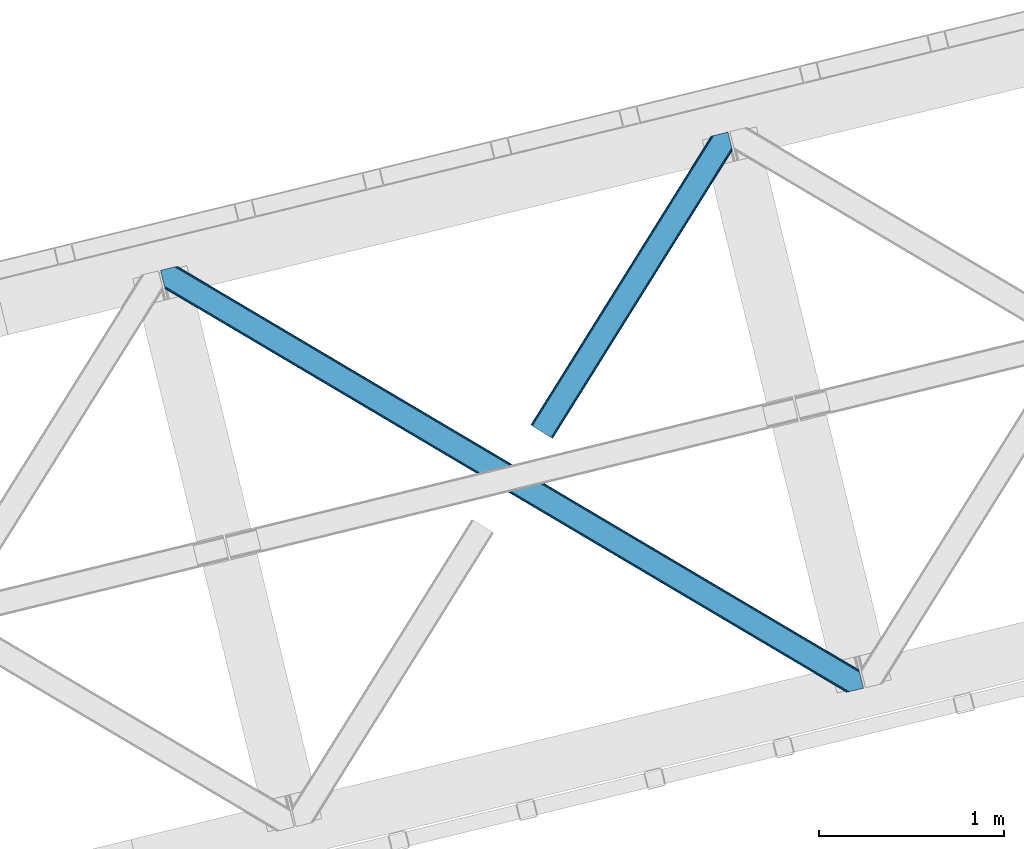
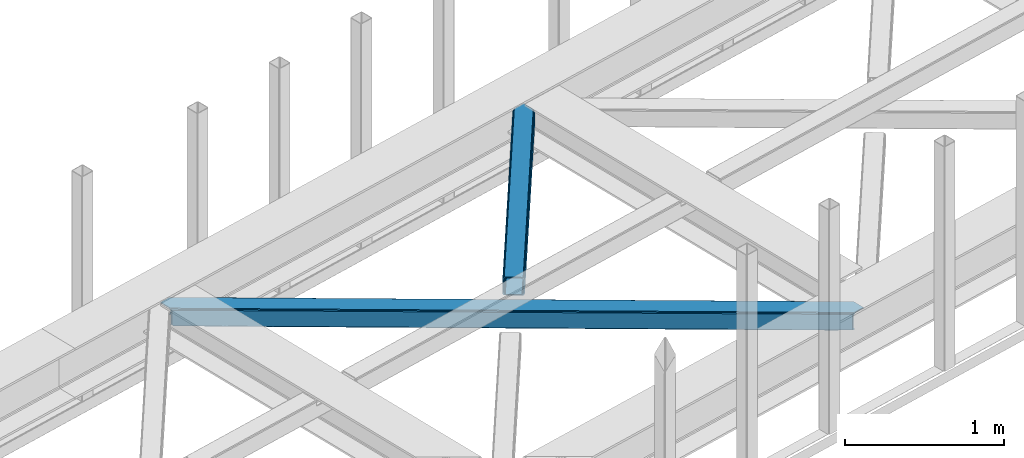
# One storey, part 45 of 67: 2 members.
"""IFC4 building model written with IfcOpenShell, lengths in millimetres."""

from ifc_helpers import new_model, entity, si_unit, converted_unit, derived_unit, direction, frame, origin, place, context, subcontext, project, spatial, triangles, type_object, element, save


model = new_model("IFC4")

# Units and contexts
model_context = context("Model", 3, precision=0.01, world=origin(), true_north=direction((6.12303176911189e-17, 1.0)))
plan_context = context("Plan", 3, precision=0.01, world=origin(), true_north=direction((6.12303176911189e-17, 1.0)))
body_context = subcontext(model_context, "Body", "Model", "MODEL_VIEW")
ifc_project = project(units=[si_unit("LENGTHUNIT", "METRE", prefix="MILLI"), si_unit("AREAUNIT", "SQUARE_METRE"), si_unit("VOLUMEUNIT", "CUBIC_METRE"), converted_unit("PLANEANGLEUNIT", "DEGREE", entity("IfcRatioMeasure", 0.0174532925199433), si_unit("PLANEANGLEUNIT", "RADIAN"), dimensions=[0, 0, 0, 0, 0, 0, 0]), si_unit("MASSUNIT", "GRAM", prefix="KILO"), derived_unit("MASSDENSITYUNIT", [(si_unit("MASSUNIT", "GRAM", prefix="KILO"), 1), (si_unit("LENGTHUNIT", "METRE"), -3)]), derived_unit("MOMENTOFINERTIAUNIT", [(si_unit("LENGTHUNIT", "METRE"), 4)]), si_unit("TIMEUNIT", "SECOND"), si_unit("FREQUENCYUNIT", "HERTZ"), si_unit("THERMODYNAMICTEMPERATUREUNIT", "DEGREE_CELSIUS"), derived_unit("THERMALTRANSMITTANCEUNIT", [(si_unit("MASSUNIT", "GRAM", prefix="KILO"), 1), (si_unit("THERMODYNAMICTEMPERATUREUNIT", "KELVIN"), -1), (si_unit("TIMEUNIT", "SECOND"), -3)]), derived_unit("VOLUMETRICFLOWRATEUNIT", [(si_unit("LENGTHUNIT", "METRE"), 3), (si_unit("TIMEUNIT", "SECOND"), -1)]), derived_unit("MASSFLOWRATEUNIT", [(si_unit("MASSUNIT", "GRAM", prefix="KILO"), 1), (si_unit("TIMEUNIT", "SECOND"), -1)]), derived_unit("ROTATIONALFREQUENCYUNIT", [(si_unit("TIMEUNIT", "SECOND"), -1)]), si_unit("ELECTRICCURRENTUNIT", "AMPERE"), si_unit("ELECTRICVOLTAGEUNIT", "VOLT"), si_unit("POWERUNIT", "WATT"), si_unit("FORCEUNIT", "NEWTON", prefix="KILO"), si_unit("ILLUMINANCEUNIT", "LUX"), si_unit("LUMINOUSFLUXUNIT", "LUMEN"), si_unit("LUMINOUSINTENSITYUNIT", "CANDELA"), derived_unit("USERDEFINED", [(si_unit("MASSUNIT", "GRAM", prefix="KILO"), -1), (si_unit("LENGTHUNIT", "METRE"), -2), (si_unit("TIMEUNIT", "SECOND"), 3), (si_unit("LUMINOUSFLUXUNIT", "LUMEN"), 1)]), derived_unit("LINEARVELOCITYUNIT", [(si_unit("LENGTHUNIT", "METRE"), 1), (si_unit("TIMEUNIT", "SECOND"), -1)]), si_unit("PRESSUREUNIT", "PASCAL"), derived_unit("USERDEFINED", [(si_unit("LENGTHUNIT", "METRE"), -2), (si_unit("MASSUNIT", "GRAM", prefix="KILO"), 1), (si_unit("TIMEUNIT", "SECOND"), -2)]), derived_unit("LINEARFORCEUNIT", [(si_unit("MASSUNIT", "GRAM", prefix="KILO"), 1), (si_unit("LENGTHUNIT", "METRE"), 1), (si_unit("TIMEUNIT", "SECOND"), -2), (si_unit("LENGTHUNIT", "METRE"), -1)]), derived_unit("PLANARFORCEUNIT", [(si_unit("MASSUNIT", "GRAM", prefix="KILO"), 1), (si_unit("LENGTHUNIT", "METRE"), 1), (si_unit("TIMEUNIT", "SECOND"), -2), (si_unit("LENGTHUNIT", "METRE"), -2)])], contexts=[model_context, plan_context])

# Site, building, storey
site_placement = place(None, origin())
site = spatial("IfcSite", under=ifc_project, at=site_placement, CompositionType="ELEMENT")
building_placement = place(site_placement, origin())
building = spatial("IfcBuilding", under=site, at=building_placement, CompositionType="ELEMENT")
storey_placement = place(building_placement, frame((0.0, 0.0, 19800.0)))
storey = spatial("IfcBuildingStorey", under=building, at=storey_placement, CompositionType="ELEMENT", Elevation=19800.0)

# Members
member_type_1 = type_object("IfcMemberType", PredefinedType="BRACE")
member_1_placement = place(storey_placement, frame((-18949.8456481934, 14772.5982971191, 3822.99993896484)))
element("IfcMember", 1, at=member_1_placement, inside=storey, type_object=member_type_1, ObjectType="Steel Horizontal Brace", PredefinedType="BRACE", context=body_context, shape_type="Tessellation", body=[
    triangles([(933.016305541994, 1535.69114685059, 0.0), (967.77581176758, 1393.09054870606, 0.0), (14.8444427490249, 64.8692962646492, 0.0), (103.913424682618, 9.26687622070313, 0.0), (928.799121093751, 1552.99009094238, 5.49966430664063), (928.938647460938, 1552.41570739746, 5.208984375), (930.798999023438, 1544.78594055176, 1.33247680664135), (971.99299621582, 1375.79160461426, 5.49966430664063), (971.852307128906, 1376.36715087891, 5.208984375), (969.993118286133, 1383.99575500488, 1.33247680664135), (972.208099365234, 1375.53813171387, 5.8531311035149), (972.418551635743, 1375.28233337402, 6.20659790039281), (928.911904907229, 1553.56912536621, 5.74383544921875), (972.720858764649, 1375.53696899414, 6.35310058593677), (929.027014160158, 1554.17606506348, 5.9996337890625), (973.022003173828, 1375.79160461426, 6.49960327148438), (929.142123413087, 1554.78300476074, 6.25543212890625), (929.250256347656, 1555.36203918457, 6.49960327148438), (4.34740905761646, 71.4223846435561, 5.12526855468968), (1.13016357422021, 73.4315643310547, 10.8039916992202), (973.355703735353, 1630.84231567383, 10.8039916992202), (976.91130065918, 1631.70854187012, 6.49960327148438), (9.16455688476708, 68.4167541503921, 1.33247680664135), (971.503491210937, 1630.3900177002, 17.5012573242202), (0.0, 74.1373352050796, 17.5012573242202), (1081.09680175781, 1548.91592102051, 6.49960327148438), (1056.20297241211, 1651.03759460449, 6.49960327148438), (971.503491210937, 1630.3900177002, 122.499499511719), (0.0, 74.1373352050796, 122.499499511719), (973.355703735353, 1630.84231567383, 129.196765136719), (1.13016357422021, 73.4315643310547, 129.196765136719), (978.633288574219, 1632.12828369141, 134.87548828125), (4.34740905761646, 71.4223846435561, 134.87548828125), (986.526992797852, 1634.05258483887, 138.668280029298), (9.16455688476708, 68.4167541503921, 138.668280029298), (995.835726928712, 1636.32221374512, 140.00075683594), (14.8444427490249, 64.8692962646492, 140.00075683594), (118.757867431643, 0.0, 17.5012573242202), (117.62886657715, 0.705770874024893, 10.8039916992202), (1085.13725280762, 1551.24949951172, 10.9783996582046), (1087.41153259277, 1552.56337280274, 13.4991760253906), (109.594473266603, 5.7205810546875, 1.33247680664135), (114.410458374023, 2.71495056152344, 5.12526855468968), (1087.56501159668, 1551.93434143066, 17.5012573242202), (1081.77234191895, 1575.70149536133, 140.00075683594), (1063.00372009277, 1652.69447021484, 140.00075683594), (103.913424682618, 9.26687622070313, 140.00075683594), (1083.9896484375, 1566.60553894043, 138.668280029298), (109.594473266603, 5.7205810546875, 138.668280029298), (1085.86860351562, 1558.8955444336, 134.87548828125), (114.410458374023, 2.71495056152344, 134.87548828125), (1087.12434082031, 1553.7435333252, 129.196765136719), (117.62886657715, 0.705770874024893, 129.196765136719), (1087.56501159668, 1551.93434143066, 122.499499511719), (118.757867431643, 0.0, 122.499499511719), (1082.5362487793, 1566.77297058106, 12.1248413085959), (1083.96058044434, 1566.72297363281, 13.4991760253906), (1077.84700012207, 1569.98440246582, 8.3320495605476), (1074.64603271485, 1577.50138549805, 6.99957275390625), (1056.69131469727, 1651.1561920166, 6.99957275390625), (1005.56885375977, 1638.69416198731, 6.99957275390625), (20.7789642333992, 61.1625457763676, 6.99957275390625), (97.9742523193381, 12.9736267089847, 6.99957275390625), (108.471286010743, 6.42053833007958, 12.1248413085959), (111.689694213866, 4.41252136230469, 17.8035644531265), (1084.80704040527, 1563.24992980957, 17.8035644531265), (103.65530090332, 9.42733154296911, 8.3320495605476), (1085.24771118164, 1561.44073791504, 24.5008300781265), (112.818695068359, 3.70675048828161, 24.5008300781265), (983.088830566408, 1633.21426391602, 17.8035644531265), (981.235455322265, 1632.76312866211, 24.5008300781265), (7.06468505859448, 69.7236511230476, 17.8035644531265), (5.93568420410156, 70.4294219970707, 24.5008300781265), (988.366415405275, 1634.50139465332, 12.1248413085959), (10.283093261718, 67.7144714355472, 12.1248413085959), (996.260119628907, 1636.42569580078, 8.3320495605476), (15.0990783691414, 64.7088409423832, 8.3320495605476), (981.235455322265, 1632.76312866211, 115.499926757813), (5.93568420410156, 70.4294219970707, 115.499926757813), (996.260119628907, 1636.42569580078, 131.668707275392), (1005.56885375977, 1638.69416198731, 133.001184082033), (1063.00372009277, 1652.69447021484, 133.001184082033), (988.366415405275, 1634.50139465332, 127.873590087893), (983.088830566408, 1633.21426391602, 122.197192382813), (20.7789642333992, 61.1625457763676, 133.001184082033), (15.0990783691414, 64.7088409423832, 131.668707275392), (10.283093261718, 67.7144714355472, 127.873590087893), (7.06468505859448, 69.7236511230476, 122.197192382813), (108.471286010743, 6.42053833007958, 127.873590087893), (111.689694213866, 4.41252136230469, 122.197192382813), (112.818695068359, 3.70675048828161, 115.499926757813), (97.9742523193381, 12.9736267089847, 133.001184082033), (103.65530090332, 9.42733154296911, 131.668707275392), (1085.24771118164, 1561.44073791504, 115.499926757813), (1084.80704040527, 1563.24992980957, 122.197192382813), (1083.55130310059, 1568.40194091797, 127.873590087893), (1081.67118530273, 1576.11309814453, 131.668707275392), (1079.45504150391, 1585.2078918457, 133.001184082033)], [[1, 2, 3], [4, 3, 2], [1, 5, 2], [6, 5, 1], [1, 7, 6], [2, 5, 8], [8, 9, 2], [10, 2, 9], [11, 8, 5], [12, 11, 13], [14, 12, 15], [16, 14, 17], [17, 18, 16], [15, 17, 14], [13, 15, 12], [5, 13, 11], [17, 19, 18], [19, 17, 15], [13, 19, 15], [19, 13, 5], [5, 6, 19], [20, 21, 18], [18, 19, 20], [21, 22, 18], [19, 6, 7], [7, 1, 23], [3, 23, 1], [7, 23, 19], [24, 21, 20], [20, 25, 24], [18, 26, 16], [26, 18, 22], [27, 26, 22], [28, 24, 25], [25, 29, 28], [30, 28, 31], [29, 31, 28], [32, 30, 33], [31, 33, 30], [34, 32, 35], [33, 35, 32], [36, 34, 37], [35, 37, 34], [38, 39, 40], [40, 41, 38], [42, 10, 9], [39, 12, 16], [16, 40, 39], [16, 26, 40], [9, 39, 43], [9, 12, 39], [9, 43, 42], [2, 10, 4], [42, 4, 10], [41, 44, 38], [45, 36, 37], [36, 45, 46], [37, 47, 45], [48, 45, 47], [47, 49, 48], [50, 48, 49], [49, 51, 50], [52, 50, 51], [51, 53, 52], [54, 52, 53], [53, 55, 54], [44, 54, 38], [55, 38, 54], [56, 40, 26], [41, 40, 56], [56, 57, 41], [58, 26, 59], [26, 58, 56], [60, 59, 26], [59, 61, 62], [61, 59, 60], [62, 63, 59], [64, 65, 66], [66, 57, 64], [58, 59, 63], [63, 67, 58], [56, 58, 67], [67, 64, 56], [57, 56, 64], [68, 66, 65], [65, 69, 68], [70, 71, 72], [73, 72, 71], [74, 70, 75], [72, 75, 70], [76, 74, 77], [75, 77, 74], [61, 76, 62], [77, 62, 76], [71, 78, 79], [79, 73, 71], [34, 36, 80], [46, 81, 36], [81, 46, 82], [81, 80, 36], [83, 34, 80], [83, 32, 34], [32, 84, 30], [84, 32, 83], [28, 84, 78], [84, 28, 30], [61, 22, 76], [70, 74, 22], [74, 76, 22], [61, 60, 22], [71, 70, 24], [21, 24, 70], [28, 71, 24], [71, 28, 78], [70, 22, 21], [80, 81, 85], [85, 86, 80], [83, 80, 86], [86, 87, 83], [84, 83, 87], [87, 88, 84], [78, 84, 88], [88, 79, 78], [53, 89, 90], [91, 38, 55], [53, 90, 55], [53, 51, 89], [90, 91, 55], [89, 51, 49], [92, 47, 37], [47, 93, 49], [93, 47, 92], [93, 89, 49], [39, 64, 43], [69, 38, 91], [38, 65, 39], [65, 38, 69], [39, 65, 64], [4, 63, 3], [42, 43, 64], [64, 67, 42], [67, 63, 4], [4, 42, 67], [87, 35, 33], [37, 85, 92], [37, 86, 85], [86, 37, 35], [87, 86, 35], [79, 29, 25], [31, 88, 87], [33, 31, 87], [88, 31, 29], [79, 88, 29], [23, 75, 19], [3, 63, 62], [62, 77, 3], [77, 75, 23], [23, 3, 77], [20, 19, 75], [25, 73, 79], [72, 25, 20], [25, 72, 73], [72, 20, 75], [66, 41, 57], [54, 44, 68], [44, 66, 68], [68, 94, 54], [44, 41, 66], [95, 54, 94], [52, 54, 95], [50, 95, 96], [95, 50, 52], [96, 48, 50], [97, 48, 96], [97, 98, 45], [97, 45, 48], [98, 46, 45], [98, 82, 46], [81, 98, 85], [81, 82, 98], [92, 85, 98], [95, 94, 90], [91, 90, 94], [96, 95, 89], [90, 89, 95], [97, 96, 93], [89, 93, 96], [98, 97, 92], [93, 92, 97], [94, 68, 69], [69, 91, 94]]),
])
member_type_2 = type_object("IfcMemberType", PredefinedType="BRACE")
member_2_placement = place(storey_placement, frame((-20945.2866394043, 13404.2934448242, 3822.99993896484)))
element("IfcMember", 2, at=member_2_placement, inside=storey, type_object=member_type_2, ObjectType="Steel Horizontal Brace", PredefinedType="BRACE", context=body_context, shape_type="Tessellation", body=[
    triangles([(3167.12993774414, 476.931353759765, 17.5012573242202), (3764.84694213867, 123.064581298828, 122.499499511719), (3764.84694213867, 123.064581298828, 17.5012573242202), (2547.33753662109, 843.863607788086, 17.5012573242202), (1927.54397277832, 1210.79469909668, 17.5012573242202), (91.5013916015632, 2297.77602539063, 122.499499511719), (687.960333251955, 1944.65920715332, 17.5012573242202), (91.5013916015632, 2297.77602539063, 17.5012573242202), (1307.752734375, 1577.726953125, 17.5012573242202), (3770.64077453613, 99.2985900878903, 140.00075683594), (3768.42346801758, 108.393383789062, 138.668280029298), (76.4813781738267, 2294.11462097168, 138.668280029298), (67.167993164061, 2291.84499206543, 140.00075683594), (3766.54451293945, 116.103378295898, 134.87548828125), (84.376245117186, 2296.03892211914, 134.87548828125), (3765.28877563477, 121.255389404296, 129.196765136719), (89.6480163574233, 2297.32489013672, 129.196765136719), (3722.24024047852, 5.93103332519422, 140.00075683594), (18.7686218261733, 2198.47743530274, 140.00075683594), (3789.40823364258, 22.3044525146488, 140.00075683594), (0.0, 2275.47157287598, 140.00075683594), (3697.90800476074, 0.0, 122.499499511719), (3699.76021728515, 0.451135253906614, 129.196765136719), (24.1217834472664, 2176.52063598633, 129.196765136719), (24.5612915039055, 2174.7114440918, 122.499499511719), (3705.03780212402, 1.73826599121094, 134.87548828125), (22.8660461425789, 2181.67264709473, 134.87548828125), (3712.93150634766, 3.66256713867188, 138.668280029298), (20.9847656249985, 2189.38264160156, 138.668280029298), (1862.08285217285, 1086.85342712402, 17.5012573242202), (2481.94152832031, 719.882803344726, 17.5012573242202), (3101.8013671875, 352.913342285156, 17.5012573242202), (3697.90800476074, 0.0, 17.5012573242202), (1242.2288269043, 1453.82521362305, 17.5012573242202), (622.368988037109, 1820.79467468262, 17.5012573242202), (24.5612915039055, 2174.7114440918, 17.5012573242202), (74.641955566407, 2293.66697387695, 127.873590087893), (66.7494140624985, 2291.74267272949, 131.668707275392), (79.9160522460952, 2294.9517791748, 122.197192382813), (57.4360290527329, 2289.47188110352, 133.001184082033), (0.0, 2275.47157287598, 133.001184082033), (81.7694274902351, 2295.40291442871, 115.499926757813), (81.7694274902351, 2295.40291442871, 24.5008300781265), (79.9160522460952, 2294.9517791748, 17.8035644531265), (89.5619750976548, 2297.30396118164, 10.8156188964858), (89.473608398439, 2297.28186950684, 10.4993591308594), (74.1140808105483, 2293.53791198731, 12.4271484375022), (72.0351379394524, 2293.03096618652, 10.4993591308594), (1922.19197387695, 1205.8275604248, 24.5008300781265), (3767.16424255371, 113.558184814452, 115.499926757813), (2545.11209106445, 837.046582031249, 24.5008300781265), (3168.02639465332, 468.263278198241, 24.5008300781265), (3767.16424255371, 113.558184814452, 24.5008300781265), (1299.27883300781, 1574.60970153809, 24.5008300781265), (676.358715820312, 1943.39067993164, 24.5008300781265), (3767.6060760498, 111.748992919922, 122.197192382813), (3768.86181335449, 106.596981811523, 127.873590087893), (3770.74076843262, 98.8869873046879, 131.668707275392), (3772.95807495117, 89.7910308837891, 133.001184082033), (3767.69444274902, 111.385061645507, 17.8686767578147), (3767.80141296387, 110.943228149414, 16.5199218750022), (3764.85624389648, 123.027374267578, 16.5199218750022), (3789.40823364258, 22.3044525146488, 133.001184082033), (3731.97336730957, 8.30414428710901, 133.001184082033), (16.4501586914048, 2207.98499450684, 133.001184082033), (162.736578369142, 2253.90544738769, 10.4993591308594), (166.88748779297, 2236.87625427246, 10.4993591308594), (3722.66463317871, 6.03451538085938, 131.668707275392), (18.6686279296882, 2198.88903808594, 131.668707275392), (3714.77092895508, 4.11021423339844, 127.873590087893), (20.547583007814, 2191.1790435791, 127.873590087893), (3709.49334411621, 2.82424621581958, 122.197192382813), (21.8033203125015, 2186.0270324707, 122.197192382813), (3707.6411315918, 2.37311096191297, 115.499926757813), (22.2451538085952, 2184.21784057617, 115.499926757813), (3114.18665771484, 353.713293457031, 24.5008300781265), (3707.6411315918, 2.37311096191297, 24.5008300781265), (2491.12120056152, 722.583801269531, 24.5008300781265), (1868.05458068848, 1091.45547180176, 24.5008300781265), (621.920178222656, 1829.19648742676, 24.5008300781265), (22.2451538085952, 2184.21784057617, 24.5008300781265), (1244.98447265625, 1460.32481689453, 24.5008300781265), (3709.49334411621, 2.82424621581958, 17.8035644531265), (3700.13577575684, 0.542990112304324, 10.8691040039084), (3700.58691101074, 0.653448486327761, 9.52034912109593), (3714.77092895508, 4.11021423339844, 12.1248413085959), (3719.39390258789, 5.23805236816406, 9.52034912109593), (21.7823913574211, 2186.11191101074, 17.817517089843), (21.7614624023445, 2186.20260314941, 17.5012573242202), (32.1398986816421, 2171.84766540527, 10.8179443359368), (28.3471069335938, 2188.73965759277, 10.4993591308594), (27.0146301269524, 2187.35253295898, 12.1248413085959), (32.4980163574219, 2171.71046447754, 10.4993591308594), (203.966619873048, 2084.76925964356, 10.4993591308594), (208.117529296876, 2067.74006652832, 10.4993591308594), (164.09696044922, 2252.5485534668, 9.49942016601563), (168.582733154297, 2234.14502563477, 9.49942016601563), (168.166479492189, 2234.81824035645, 9.74591674804833), (163.769073486328, 2252.87527770996, 9.74126586914281), (167.738598632812, 2235.51122131348, 9.9993896484375), (163.420257568359, 2253.22758178711, 9.9993896484375), (167.306066894533, 2236.20303955078, 10.2528625488303), (163.066790771485, 2253.5775604248, 10.2598388671868), (209.163977050783, 2067.67262878418, 9.49942016601563), (209.136071777342, 2067.46799011231, 9.88311767578125), (204.682855224608, 2085.44363708496, 9.8528869628899), (208.803533935548, 2067.55635681152, 10.0831054687515), (204.682855224608, 2084.81228027344, 10.2063537597678), (208.45006713867, 2067.6516998291, 10.2993713378928), (204.324737548828, 2084.79018859863, 10.3528564453118), (204.678204345702, 2086.07499389648, 9.49942016601563), (3763.57957763672, 109.728186035156, 12.1248413085959), (3758.57058105469, 124.97144165039, 10.8714294433594), (3757.06485900879, 125.435366821288, 9.52034912109593), (3761.54365539551, 107.0643951416, 9.52034912109593), (3585.92414245605, 211.034793090819, 9.52034912109593), (3581.44534606934, 229.405764770507, 9.52034912109593), (3585.50672607422, 211.134786987304, 9.44360961914208), (3581.0453704834, 229.553430175782, 9.37384643554833), (3580.64655761719, 229.701095581055, 9.22734375000073), (3580.53842468262, 229.533663940429, 8.87387695312646), (3585.45672912598, 210.476687622069, 9.13897705078125), (3580.42680358887, 229.365069580077, 8.52041015625218), (3585.40440673828, 209.805798339843, 8.82736816406396), (3585.35440979004, 209.14769897461, 8.52041015625218), (3164.51846923828, 472.521157836914, 5.12526855468968), (3581.30233154297, 225.771102905273, 5.12526855468968), (3166.45090942383, 475.784912109375, 10.8039916992202), (687.281304931639, 1943.51276550293, 10.8039916992202), (685.348864746094, 1940.24901123047, 5.12526855468968), (165.152709960938, 2248.21625976562, 5.12526855468968), (682.456018066405, 1935.36326293945, 1.33247680664135), (167.033990478514, 2240.50510253906, 1.33247680664135), (679.044598388671, 1929.60082397461, 0.0), (169.250134277343, 2231.41030883789, 0.0), (3583.18128662109, 218.061108398437, 1.33247680664135), (3585.39859313965, 208.966314697265, 0.0), (3158.21536560059, 461.872970581055, 0.0), (3161.62562255859, 467.635409545897, 1.33247680664135), (2546.65850830078, 842.717166137694, 10.8039916992202), (1926.86610717774, 1209.64942016602, 10.8039916992202), (1307.07370605469, 1576.58051147461, 10.8039916992202), (2544.72606811523, 839.452249145508, 5.12526855468968), (1924.93366699219, 1206.38450317383, 5.12526855468968), (1305.14126586914, 1573.31675720215, 5.12526855468968), (2541.83322143555, 834.567663574218, 1.33247680664135), (1922.0408203125, 1201.49875488281, 1.33247680664135), (1302.24841918945, 1568.43100891113, 1.33247680664135), (2538.42296447754, 828.804061889648, 0.0), (1918.63056335449, 1195.73631591797, 0.0), (1298.83699951172, 1562.66856994629, 0.0), (3620.15926208496, 66.3657165527347, 0.0), (3110.71477661133, 367.971725463867, 0.0), (2490.85610046387, 734.942349243163, 0.0), (1871.00091247559, 1101.91297302246, 0.0), (631.282397460938, 1835.85305786133, 0.0), (1251.14223632812, 1468.88359680176, 0.0), (204.010803222656, 2088.80971069336, 0.0), (3167.34852905274, 467.117999267577, 17.8035644531265), (3165.41492614746, 463.853082275391, 12.1248413085959), (673.747247314452, 1938.98048400879, 12.1248413085959), (675.6796875, 1942.24540100098, 17.8035644531265), (670.854400634766, 1934.09473571777, 8.3320495605476), (169.398962402345, 2230.8022064209, 8.81806640624927), (171.566271972657, 2221.90391235351, 6.99957275390625), (3159.11182250977, 453.204895019531, 6.99957275390625), (3587.71589355469, 199.458755493164, 6.99957275390625), (3585.50672607422, 208.524481201172, 8.42274169921802), (3162.5232421875, 458.967333984374, 8.3320495605476), (667.442980957032, 1928.33229675293, 6.99957275390625), (2539.60777587891, 827.750637817382, 8.3320495605476), (2536.1975189209, 821.987036132812, 6.99957275390625), (1916.68882141113, 1196.53161621094, 8.3320495605476), (1913.2774017334, 1190.76917724609, 6.99957275390625), (1290.36309814453, 1559.55131835938, 6.99957275390625), (1293.77451782226, 1565.31375732422, 8.3320495605476), (2542.50062255859, 832.635223388672, 12.1248413085959), (1919.58166809082, 1201.41736450195, 12.1248413085959), (1296.66736450195, 1570.19950561523, 12.1248413085959), (2544.43306274414, 835.90014038086, 17.8035644531265), (1921.51410827637, 1204.68111877441, 17.8035644531265), (1298.5998046875, 1573.4632598877, 17.8035644531265), (201.692340087891, 2098.31726989746, 6.99957275390625), (203.861975097658, 2089.41781311035, 8.81806640624927), (206.226947021485, 2079.71491699219, 1.33247680664135), (208.105902099611, 2072.00492248535, 5.12526855468968), (2500.03460998535, 737.643347167968, 6.99957275390625), (3123.1012298584, 368.771676635743, 6.99957275390625), (1876.96915283203, 1106.51385498047, 6.99957275390625), (3617.84196166992, 75.8721130371086, 6.99957275390625), (630.833587646484, 1844.25487060547, 6.99957275390625), (1253.90020751953, 1475.38320007324, 6.99957275390625), (3119.68981018067, 363.009237670898, 8.3320495605476), (3620.5638885498, 65.041378784179, 8.90410766601781), (3620.20344543457, 66.183169555663, 8.52041015625218), (3116.79696350098, 358.123489379883, 12.1248413085959), (3621.05455627442, 64.3216552734375, 9.1087463378899), (3621.55336303711, 63.5937927246086, 9.31571044922021), (3622.03937988281, 62.8729064941399, 9.52034912109593), (3620.05112915039, 66.8075500488285, 8.42274169921802), (624.529321289061, 1833.60668334961, 12.1248413085959), (627.422167968751, 1838.49243164063, 8.3320495605476), (622.596881103516, 1830.34176635742, 17.8035644531265), (3114.86452331543, 354.859735107422, 17.8035644531265), (2491.79906616211, 723.730242919921, 17.8035644531265), (1868.73360900879, 1092.60075073242, 17.8035644531265), (1245.66350097656, 1461.47125854492, 17.8035644531265), (2493.73150634766, 726.995159912109, 12.1248413085959), (1870.66604919434, 1095.86566772461, 12.1248413085959), (1247.59594116211, 1464.73617553711, 12.1248413085959), (2496.62435302734, 731.879745483398, 8.3320495605476), (1873.55889587402, 1100.75141601562, 8.3320495605476), (1250.4887878418, 1469.6207611084, 8.3320495605476), (3102.47923278809, 354.059783935547, 10.8039916992202), (624.980456542969, 1825.20487060547, 5.12526855468968), (623.04569091797, 1821.94111633301, 10.8039916992202), (3626.51817626953, 44.5019348144524, 9.52034912109593), (3104.41167297363, 357.323538208007, 5.12526855468968), (3624.25552368164, 49.5597656249993, 5.12526855468968), (3625.13105163574, 45.9669616699211, 8.52041015625218), (3625.82752075195, 45.2344482421868, 9.02037963867406), (3622.37656860351, 57.2709228515614, 1.33247680664135), (3107.30451965332, 362.209286499023, 1.33247680664135), (627.870977783205, 1830.09061889648, 1.33247680664135), (2487.44468078613, 729.179910278321, 1.33247680664135), (1867.58600463867, 1096.14937133789, 1.33247680664135), (1247.73081665039, 1463.12115783691, 1.33247680664135), (2484.55299682617, 724.294161987304, 5.12526855468968), (1864.69315795898, 1091.26362304687, 5.12526855468968), (1244.8379699707, 1458.2354095459, 5.12526855468968), (2482.6193939209, 721.029244995118, 10.8039916992202), (1862.76536865234, 1088.00103149414, 10.8039916992202), (1242.90552978516, 1454.97049255371, 10.8039916992202)], [[1, 2, 3], [2, 1, 4], [2, 5, 6], [5, 2, 4], [7, 8, 6], [9, 6, 5], [6, 9, 7], [10, 11, 12], [12, 13, 10], [11, 14, 15], [15, 12, 11], [14, 16, 17], [17, 15, 14], [16, 2, 6], [6, 17, 16], [18, 10, 19], [18, 20, 10], [13, 19, 10], [21, 19, 13], [22, 23, 24], [24, 25, 22], [23, 26, 27], [27, 24, 23], [26, 28, 29], [29, 27, 26], [28, 18, 19], [19, 29, 28], [30, 22, 25], [22, 31, 32], [30, 31, 22], [32, 33, 22], [34, 25, 35], [25, 34, 30], [36, 35, 25], [37, 38, 12], [15, 37, 12], [15, 17, 39], [37, 15, 39], [39, 17, 6], [38, 13, 12], [21, 40, 41], [21, 13, 40], [38, 40, 13], [39, 6, 42], [43, 8, 44], [6, 43, 42], [8, 45, 44], [6, 8, 43], [46, 44, 45], [46, 47, 44], [46, 48, 47], [49, 50, 42], [50, 51, 52], [49, 51, 50], [52, 53, 50], [54, 42, 55], [42, 54, 49], [43, 55, 42], [50, 56, 42], [39, 42, 56], [56, 57, 39], [37, 39, 57], [57, 58, 37], [38, 37, 58], [58, 59, 38], [40, 38, 59], [57, 14, 11], [59, 58, 10], [58, 57, 11], [60, 61, 62], [63, 59, 20], [10, 20, 59], [58, 11, 10], [60, 3, 53], [2, 50, 53], [53, 3, 2], [60, 62, 3], [2, 56, 50], [56, 14, 57], [14, 56, 16], [2, 16, 56], [59, 64, 65], [64, 59, 63], [65, 40, 59], [41, 40, 65], [66, 67, 46], [48, 46, 67], [64, 68, 65], [69, 65, 68], [68, 70, 69], [71, 69, 70], [70, 72, 71], [73, 71, 72], [72, 74, 73], [75, 73, 74], [76, 74, 77], [74, 76, 78], [74, 79, 75], [79, 74, 78], [80, 81, 75], [82, 75, 79], [75, 82, 80], [70, 68, 28], [26, 70, 28], [26, 23, 72], [70, 26, 72], [72, 23, 22], [68, 18, 28], [20, 64, 63], [20, 18, 64], [68, 64, 18], [72, 22, 74], [77, 33, 83], [22, 77, 74], [33, 84, 83], [22, 33, 77], [85, 83, 84], [86, 83, 85], [87, 86, 85], [73, 75, 25], [25, 24, 73], [27, 73, 24], [73, 27, 71], [25, 81, 36], [88, 89, 36], [36, 81, 88], [75, 81, 25], [69, 29, 19], [21, 65, 19], [41, 65, 21], [69, 71, 29], [29, 71, 27], [65, 69, 19], [90, 91, 92], [90, 93, 91], [92, 36, 90], [89, 36, 92], [94, 95, 93], [93, 91, 94], [96, 97, 98], [98, 99, 96], [99, 98, 100], [100, 101, 99], [101, 100, 102], [102, 103, 101], [103, 102, 67], [67, 66, 103], [104, 105, 106], [105, 107, 108], [108, 107, 109], [110, 109, 95], [95, 94, 110], [109, 110, 108], [108, 106, 105], [106, 111, 104], [62, 112, 113], [112, 62, 61], [112, 114, 113], [112, 115, 114], [114, 115, 116], [116, 117, 114], [118, 119, 117], [120, 119, 118], [121, 120, 122], [123, 121, 124], [124, 125, 123], [122, 124, 121], [118, 122, 120], [117, 116, 118], [1, 3, 113], [3, 62, 113], [120, 121, 126], [123, 126, 121], [123, 127, 126], [128, 113, 117], [117, 126, 128], [117, 119, 126], [120, 126, 119], [113, 114, 117], [45, 129, 66], [129, 130, 131], [131, 96, 129], [129, 99, 101], [99, 129, 96], [129, 103, 66], [103, 129, 101], [129, 45, 8], [8, 7, 129], [66, 46, 45], [130, 132, 133], [133, 131, 130], [132, 134, 135], [135, 133, 132], [136, 137, 138], [138, 139, 136], [127, 136, 139], [139, 126, 127], [113, 128, 1], [1, 128, 4], [140, 4, 128], [4, 140, 5], [141, 5, 140], [5, 141, 9], [142, 9, 141], [9, 142, 7], [129, 7, 142], [128, 126, 143], [143, 140, 128], [140, 143, 144], [144, 141, 140], [141, 144, 145], [145, 142, 141], [142, 145, 129], [130, 129, 145], [126, 139, 146], [146, 143, 126], [143, 146, 144], [147, 144, 146], [144, 147, 145], [148, 145, 147], [145, 148, 132], [132, 130, 145], [139, 138, 146], [149, 146, 138], [146, 149, 147], [150, 147, 149], [147, 150, 151], [151, 148, 147], [148, 151, 132], [134, 132, 151], [137, 152, 153], [138, 153, 154], [153, 138, 137], [149, 155, 150], [154, 149, 138], [149, 154, 155], [156, 134, 151], [150, 157, 151], [157, 150, 155], [157, 156, 151], [158, 134, 156], [135, 134, 158], [159, 160, 112], [112, 61, 159], [159, 60, 53], [161, 162, 44], [98, 163, 100], [98, 97, 163], [163, 102, 100], [163, 67, 102], [97, 164, 163], [161, 47, 67], [67, 163, 161], [47, 48, 67], [163, 164, 165], [166, 167, 168], [160, 118, 116], [116, 112, 160], [116, 115, 112], [169, 168, 125], [125, 160, 169], [124, 122, 160], [122, 118, 160], [160, 125, 124], [168, 169, 166], [165, 170, 163], [44, 47, 161], [162, 55, 43], [43, 44, 162], [53, 52, 159], [61, 60, 159], [166, 169, 171], [171, 172, 166], [172, 171, 173], [173, 174, 172], [174, 173, 175], [176, 175, 173], [175, 176, 170], [163, 170, 176], [169, 160, 171], [177, 171, 160], [171, 177, 178], [178, 173, 171], [173, 178, 179], [179, 176, 173], [176, 179, 161], [161, 163, 176], [160, 159, 180], [180, 177, 160], [177, 180, 181], [181, 178, 177], [178, 181, 179], [182, 179, 181], [179, 182, 161], [162, 161, 182], [159, 52, 180], [51, 180, 52], [180, 51, 49], [49, 181, 180], [181, 49, 54], [54, 182, 181], [182, 54, 55], [55, 162, 182], [97, 131, 133], [135, 97, 133], [165, 164, 135], [165, 135, 183], [131, 97, 96], [135, 164, 97], [183, 158, 184], [158, 185, 111], [158, 183, 135], [186, 111, 185], [158, 111, 184], [186, 104, 111], [187, 188, 166], [166, 172, 187], [172, 189, 187], [189, 172, 174], [188, 167, 166], [188, 190, 167], [170, 191, 175], [191, 170, 183], [165, 183, 170], [192, 175, 191], [174, 192, 189], [175, 192, 174], [193, 194, 195], [196, 197, 194], [196, 198, 197], [196, 199, 198], [194, 193, 196], [195, 200, 193], [86, 87, 199], [199, 196, 86], [193, 200, 190], [191, 183, 184], [201, 108, 110], [110, 94, 201], [94, 92, 201], [94, 91, 92], [202, 106, 108], [202, 111, 106], [202, 184, 111], [108, 201, 202], [203, 201, 92], [92, 89, 203], [203, 88, 81], [81, 80, 203], [89, 88, 203], [184, 202, 191], [190, 188, 193], [83, 86, 196], [196, 204, 83], [77, 83, 204], [204, 76, 77], [76, 204, 205], [205, 78, 76], [78, 205, 206], [206, 79, 78], [79, 206, 207], [207, 82, 79], [82, 207, 80], [203, 80, 207], [204, 196, 205], [208, 205, 196], [205, 208, 206], [209, 206, 208], [206, 209, 207], [210, 207, 209], [207, 210, 201], [201, 203, 207], [196, 193, 211], [211, 208, 196], [208, 211, 212], [212, 209, 208], [209, 212, 213], [213, 210, 209], [210, 213, 202], [202, 201, 210], [193, 188, 211], [187, 211, 188], [211, 187, 212], [189, 212, 187], [212, 189, 213], [192, 213, 189], [213, 192, 202], [191, 202, 192], [214, 84, 33], [35, 36, 90], [215, 105, 104], [216, 90, 95], [95, 215, 216], [95, 107, 215], [104, 186, 215], [84, 214, 217], [214, 218, 219], [219, 220, 214], [221, 217, 214], [214, 220, 221], [217, 85, 84], [222, 219, 218], [218, 223, 222], [152, 222, 223], [223, 153, 152], [156, 224, 185], [185, 158, 156], [224, 215, 186], [186, 185, 224], [90, 216, 35], [33, 32, 214], [153, 223, 154], [225, 154, 223], [154, 225, 155], [226, 155, 225], [155, 226, 157], [227, 157, 226], [157, 227, 224], [224, 156, 157], [223, 218, 228], [228, 225, 223], [225, 228, 229], [229, 226, 225], [226, 229, 230], [230, 227, 226], [227, 230, 224], [215, 224, 230], [218, 214, 231], [231, 228, 218], [228, 231, 229], [232, 229, 231], [229, 232, 230], [233, 230, 232], [230, 233, 215], [216, 215, 233], [214, 32, 231], [31, 231, 32], [231, 31, 30], [30, 232, 231], [232, 30, 34], [34, 233, 232], [233, 34, 216], [35, 216, 34], [137, 167, 190], [125, 127, 123], [137, 125, 167], [125, 136, 127], [125, 137, 136], [152, 137, 190], [195, 152, 190], [219, 195, 220], [195, 222, 152], [195, 219, 222], [220, 195, 194], [221, 194, 197], [221, 197, 198], [217, 198, 199], [87, 85, 199], [217, 199, 85]]),
])

save(model, "model.ifc")
